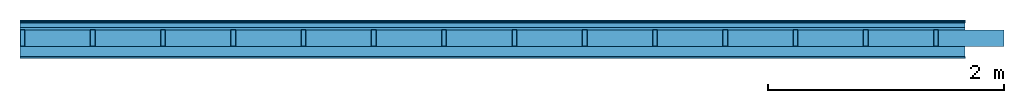
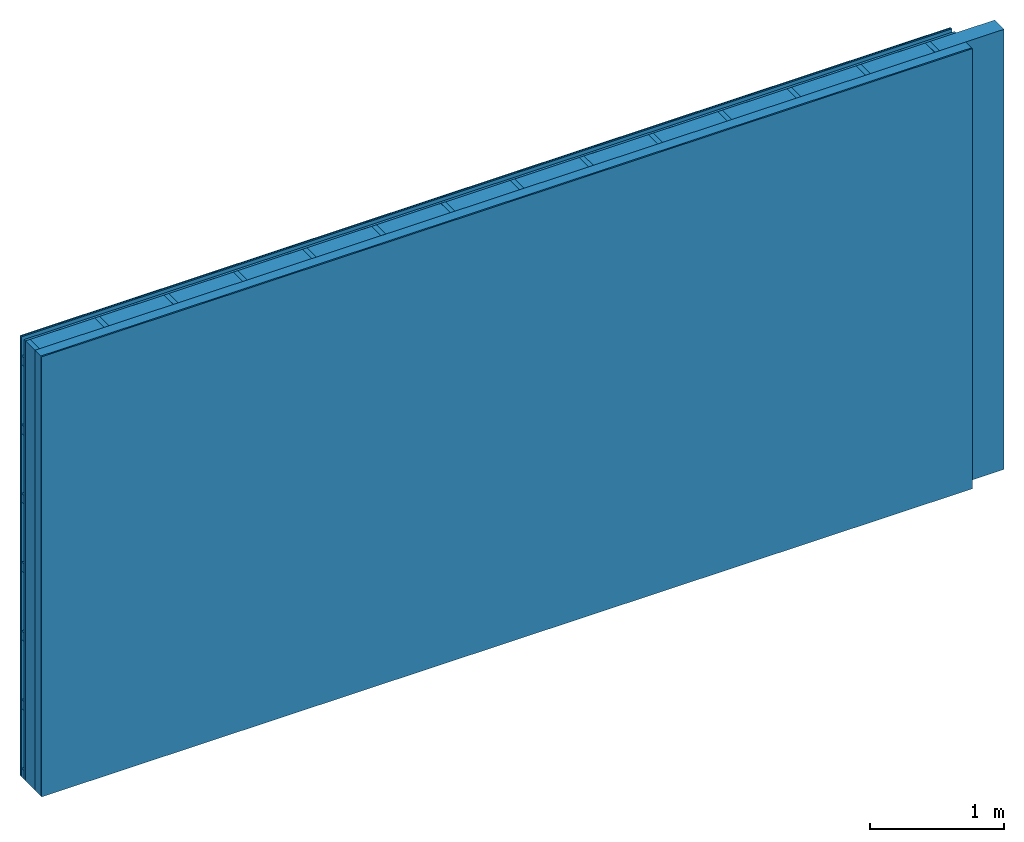
# One storey: 5 plates, 3 members, 1 element without a shape of its own.
"""IFC4 building model written with IfcOpenShell, lengths in metres."""

from ifc_helpers import new_model, si_unit, derived_unit, direction, frame, frame_2d, origin, origin_with_axes, place, context, project, spatial, rectangle, extrude, material, layer, layer_set, type_object, element, aggregate, save


model = new_model("IFC4")

# Units and contexts
plan_context = context("Plan", 3, precision=1e-05, world=origin(), true_north=direction((0.0, 1.0)))
model_context = context("Model", 3, precision=1e-05, world=origin(), true_north=direction((0.0, 1.0)))
ifc_project = project(units=[si_unit("LENGTHUNIT", "METRE"), derived_unit("SOUNDPRESSUREUNIT", [(si_unit("PRESSUREUNIT", "PASCAL", prefix="MICRO"), 0)]), si_unit("ENERGYUNIT", "JOULE", prefix="MEGA"), si_unit("MASSUNIT", "GRAM", prefix="KILO"), derived_unit("THERMALTRANSMITTANCEUNIT", [(si_unit("POWERUNIT", "WATT"), 1), (si_unit("AREAUNIT", "SQUARE_METRE"), -1), (si_unit("THERMODYNAMICTEMPERATUREUNIT", "KELVIN"), -1)]), derived_unit("AREADENSITYUNIT", [(si_unit("MASSUNIT", "GRAM", prefix="KILO"), 1), (si_unit("AREAUNIT", "SQUARE_METRE"), -1)]), derived_unit("USERDEFINED", [(si_unit("ENERGYUNIT", "JOULE", prefix="MEGA"), 1), (si_unit("AREAUNIT", "SQUARE_METRE"), -1)])], contexts=[plan_context, model_context])

# Site, building, storey
site = spatial("IfcSite", under=ifc_project)
building_placement = place(None, origin())
building = spatial("IfcBuilding", under=site, at=building_placement)
storey_placement = place(building_placement, origin())
storey = spatial("IfcBuildingStorey", under=building, at=storey_placement)

# Wall, members, plates
ifc_material_1 = material(Category="04.011")
ifc_layer_1 = layer(ifc_material_1, 0.01, Name="Surface 1")
ifc_material_2 = material(Name="mineral, cement-based building board", Category="03.003")
ifc_layer_2 = layer(ifc_material_2, 0.013, Name="Cover 1st layer")
ifc_layer_3 = layer(None, 0.04, Name="Battens / profiles (ventilation)")
ifc_material_3 = material(Category="10.009")
ifc_layer_4 = layer(ifc_material_3, 0.02, Name="outside 1st layer")
ifc_material_4 = material(Name="of the art")
ifc_layer_5 = layer(ifc_material_4, 0.0, Name="Bond")
ifc_layer_6 = layer(None, 0.14, Name="Support")
ifc_layer_7 = layer(ifc_material_4, 0.0, Name="Bond")
ifc_material_5 = material(Name="Solid timber panel")
ifc_layer_8 = layer(ifc_material_5, 0.087, Name="1st layer")
ifc_material_6 = material(Name="Plasterboard type A", Category="03.008")
ifc_layer_9 = layer(ifc_material_6, 0.0125, Name="Covering 1st layer")
ifc_material_7 = material(Name="joints", Category="04.017")
ifc_layer_10 = layer(ifc_material_7, 0.0, Name="Surface")
ifc_layer_set = layer_set([ifc_layer_1, ifc_layer_2, ifc_layer_3, ifc_layer_4, ifc_layer_5, ifc_layer_6, ifc_layer_7, ifc_layer_8, ifc_layer_9, ifc_layer_10])
wall_type = type_object("IfcWallType", Name="D0974", PredefinedType="NOTDEFINED", material=ifc_layer_set)
wall_placement = place(None, frame((0.0, 0.0, 0.0), z_axis=(0.0, -1.0, 0.0), x_axis=(1.0, 0.0, 0.0)))
wall = element("IfcWall", 1, at=wall_placement, inside=storey, type_object=wall_type, material=ifc_layer_set, Name="Wall #1")
ifc_material_8 = material()
member_1_placement = place(wall_placement, origin())
member_1 = element("IfcMember", 2, at=member_1_placement, material=ifc_material_8, Name="Battens / profiles (ventilation)", context=plan_context, shape_type="SweptSolid", body=[
    extrude(rectangle(XDim=0.08, YDim=0.04, at=frame_2d((0.04, 0.02), x_axis=(1.0, 0.0))), frame((0.0, 0.0, 0.023), z_axis=(1.0, 0.0, 0.0), x_axis=(0.0, 1.0, 0.0)), (0.0, 0.0, 1.0), 8.0),
    extrude(rectangle(XDim=0.08, YDim=0.04, at=frame_2d((0.04, 0.02), x_axis=(1.0, 0.0))), frame((0.0, 0.625, 0.023), z_axis=(1.0, 0.0, 0.0), x_axis=(0.0, 1.0, 0.0)), (0.0, 0.0, 1.0), 8.0),
    extrude(rectangle(XDim=0.08, YDim=0.04, at=frame_2d((0.04, 0.02), x_axis=(1.0, 0.0))), frame((0.0, 1.25, 0.023), z_axis=(1.0, 0.0, 0.0), x_axis=(0.0, 1.0, 0.0)), (0.0, 0.0, 1.0), 8.0),
    extrude(rectangle(XDim=0.08, YDim=0.04, at=frame_2d((0.04, 0.02), x_axis=(1.0, 0.0))), frame((0.0, 1.875, 0.023), z_axis=(1.0, 0.0, 0.0), x_axis=(0.0, 1.0, 0.0)), (0.0, 0.0, 1.0), 8.0),
    extrude(rectangle(XDim=0.08, YDim=0.04, at=frame_2d((0.04, 0.02), x_axis=(1.0, 0.0))), frame((0.0, 2.5, 0.023), z_axis=(1.0, 0.0, 0.0), x_axis=(0.0, 1.0, 0.0)), (0.0, 0.0, 1.0), 8.0),
    extrude(rectangle(XDim=0.08, YDim=0.04, at=frame_2d((0.04, 0.02), x_axis=(1.0, 0.0))), frame((0.0, 3.125, 0.023), z_axis=(1.0, 0.0, 0.0), x_axis=(0.0, 1.0, 0.0)), (0.0, 0.0, 1.0), 8.0),
    extrude(rectangle(XDim=0.08, YDim=0.04, at=frame_2d((0.04, 0.02), x_axis=(1.0, 0.0))), frame((0.0, 3.75, 0.023), z_axis=(1.0, 0.0, 0.0), x_axis=(0.0, 1.0, 0.0)), (0.0, 0.0, 1.0), 8.0),
])
ifc_material_9 = material()
member_2_placement = place(wall_placement, origin())
member_2 = element("IfcMember", 3, at=member_2_placement, material=ifc_material_9, Name="Support", context=plan_context, shape_type="SweptSolid", body=[
    extrude(rectangle(XDim=0.04, YDim=0.14, at=frame_2d((0.02, 0.07), x_axis=(1.0, 0.0))), frame((0.0, 4.0, 0.083), z_axis=(0.0, -1.0, 0.0), x_axis=(1.0, 0.0, 0.0)), (0.0, 0.0, 1.0), 4.0),
    extrude(rectangle(XDim=0.04, YDim=0.14, at=frame_2d((0.02, 0.07), x_axis=(1.0, 0.0))), frame((0.595, 4.0, 0.083), z_axis=(0.0, -1.0, 0.0), x_axis=(1.0, 0.0, 0.0)), (0.0, 0.0, 1.0), 4.0),
    extrude(rectangle(XDim=0.04, YDim=0.14, at=frame_2d((0.02, 0.07), x_axis=(1.0, 0.0))), frame((1.19, 4.0, 0.083), z_axis=(0.0, -1.0, 0.0), x_axis=(1.0, 0.0, 0.0)), (0.0, 0.0, 1.0), 4.0),
    extrude(rectangle(XDim=0.04, YDim=0.14, at=frame_2d((0.02, 0.07), x_axis=(1.0, 0.0))), frame((1.785, 4.0, 0.083), z_axis=(0.0, -1.0, 0.0), x_axis=(1.0, 0.0, 0.0)), (0.0, 0.0, 1.0), 4.0),
    extrude(rectangle(XDim=0.04, YDim=0.14, at=frame_2d((0.02, 0.07), x_axis=(1.0, 0.0))), frame((2.38, 4.0, 0.083), z_axis=(0.0, -1.0, 0.0), x_axis=(1.0, 0.0, 0.0)), (0.0, 0.0, 1.0), 4.0),
    extrude(rectangle(XDim=0.04, YDim=0.14, at=frame_2d((0.02, 0.07), x_axis=(1.0, 0.0))), frame((2.975, 4.0, 0.083), z_axis=(0.0, -1.0, 0.0), x_axis=(1.0, 0.0, 0.0)), (0.0, 0.0, 1.0), 4.0),
    extrude(rectangle(XDim=0.04, YDim=0.14, at=frame_2d((0.02, 0.07), x_axis=(1.0, 0.0))), frame((3.57, 4.0, 0.083), z_axis=(0.0, -1.0, 0.0), x_axis=(1.0, 0.0, 0.0)), (0.0, 0.0, 1.0), 4.0),
    extrude(rectangle(XDim=0.04, YDim=0.14, at=frame_2d((0.02, 0.07), x_axis=(1.0, 0.0))), frame((4.165, 4.0, 0.083), z_axis=(0.0, -1.0, 0.0), x_axis=(1.0, 0.0, 0.0)), (0.0, 0.0, 1.0), 4.0),
    extrude(rectangle(XDim=0.04, YDim=0.14, at=frame_2d((0.02, 0.07), x_axis=(1.0, 0.0))), frame((4.76, 4.0, 0.083), z_axis=(0.0, -1.0, 0.0), x_axis=(1.0, 0.0, 0.0)), (0.0, 0.0, 1.0), 4.0),
    extrude(rectangle(XDim=0.04, YDim=0.14, at=frame_2d((0.02, 0.07), x_axis=(1.0, 0.0))), frame((5.355, 4.0, 0.083), z_axis=(0.0, -1.0, 0.0), x_axis=(1.0, 0.0, 0.0)), (0.0, 0.0, 1.0), 4.0),
    extrude(rectangle(XDim=0.04, YDim=0.14, at=frame_2d((0.02, 0.07), x_axis=(1.0, 0.0))), frame((5.95, 4.0, 0.083), z_axis=(0.0, -1.0, 0.0), x_axis=(1.0, 0.0, 0.0)), (0.0, 0.0, 1.0), 4.0),
    extrude(rectangle(XDim=0.04, YDim=0.14, at=frame_2d((0.02, 0.07), x_axis=(1.0, 0.0))), frame((6.545, 4.0, 0.083), z_axis=(0.0, -1.0, 0.0), x_axis=(1.0, 0.0, 0.0)), (0.0, 0.0, 1.0), 4.0),
    extrude(rectangle(XDim=0.04, YDim=0.14, at=frame_2d((0.02, 0.07), x_axis=(1.0, 0.0))), frame((7.14, 4.0, 0.083), z_axis=(0.0, -1.0, 0.0), x_axis=(1.0, 0.0, 0.0)), (0.0, 0.0, 1.0), 4.0),
    extrude(rectangle(XDim=0.04, YDim=0.14, at=frame_2d((0.02, 0.07), x_axis=(1.0, 0.0))), frame((7.735, 4.0, 0.083), z_axis=(0.0, -1.0, 0.0), x_axis=(1.0, 0.0, 0.0)), (0.0, 0.0, 1.0), 4.0),
])
ifc_material_10 = material()
member_3_placement = place(wall_placement, origin())
member_3 = element("IfcMember", 4, at=member_3_placement, material=ifc_material_10, Name="Cavity", context=plan_context, shape_type="SweptSolid", body=[
    extrude(rectangle(XDim=0.555, YDim=0.14, at=frame_2d((0.2775, 0.07), x_axis=(1.0, 0.0))), frame((0.04, 4.0, 0.083), z_axis=(0.0, -1.0, 0.0), x_axis=(1.0, 0.0, 0.0)), (0.0, 0.0, 1.0), 4.0),
    extrude(rectangle(XDim=0.555, YDim=0.14, at=frame_2d((0.2775, 0.07), x_axis=(1.0, 0.0))), frame((0.635, 4.0, 0.083), z_axis=(0.0, -1.0, 0.0), x_axis=(1.0, 0.0, 0.0)), (0.0, 0.0, 1.0), 4.0),
    extrude(rectangle(XDim=0.555, YDim=0.14, at=frame_2d((0.2775, 0.07), x_axis=(1.0, 0.0))), frame((1.23, 4.0, 0.083), z_axis=(0.0, -1.0, 0.0), x_axis=(1.0, 0.0, 0.0)), (0.0, 0.0, 1.0), 4.0),
    extrude(rectangle(XDim=0.555, YDim=0.14, at=frame_2d((0.2775, 0.07), x_axis=(1.0, 0.0))), frame((1.825, 4.0, 0.083), z_axis=(0.0, -1.0, 0.0), x_axis=(1.0, 0.0, 0.0)), (0.0, 0.0, 1.0), 4.0),
    extrude(rectangle(XDim=0.555, YDim=0.14, at=frame_2d((0.2775, 0.07), x_axis=(1.0, 0.0))), frame((2.42, 4.0, 0.083), z_axis=(0.0, -1.0, 0.0), x_axis=(1.0, 0.0, 0.0)), (0.0, 0.0, 1.0), 4.0),
    extrude(rectangle(XDim=0.555, YDim=0.14, at=frame_2d((0.2775, 0.07), x_axis=(1.0, 0.0))), frame((3.015, 4.0, 0.083), z_axis=(0.0, -1.0, 0.0), x_axis=(1.0, 0.0, 0.0)), (0.0, 0.0, 1.0), 4.0),
    extrude(rectangle(XDim=0.555, YDim=0.14, at=frame_2d((0.2775, 0.07), x_axis=(1.0, 0.0))), frame((3.61, 4.0, 0.083), z_axis=(0.0, -1.0, 0.0), x_axis=(1.0, 0.0, 0.0)), (0.0, 0.0, 1.0), 4.0),
    extrude(rectangle(XDim=0.555, YDim=0.14, at=frame_2d((0.2775, 0.07), x_axis=(1.0, 0.0))), frame((4.205, 4.0, 0.083), z_axis=(0.0, -1.0, 0.0), x_axis=(1.0, 0.0, 0.0)), (0.0, 0.0, 1.0), 4.0),
    extrude(rectangle(XDim=0.555, YDim=0.14, at=frame_2d((0.2775, 0.07), x_axis=(1.0, 0.0))), frame((4.8, 4.0, 0.083), z_axis=(0.0, -1.0, 0.0), x_axis=(1.0, 0.0, 0.0)), (0.0, 0.0, 1.0), 4.0),
    extrude(rectangle(XDim=0.555, YDim=0.14, at=frame_2d((0.2775, 0.07), x_axis=(1.0, 0.0))), frame((5.395, 4.0, 0.083), z_axis=(0.0, -1.0, 0.0), x_axis=(1.0, 0.0, 0.0)), (0.0, 0.0, 1.0), 4.0),
    extrude(rectangle(XDim=0.555, YDim=0.14, at=frame_2d((0.2775, 0.07), x_axis=(1.0, 0.0))), frame((5.99, 4.0, 0.083), z_axis=(0.0, -1.0, 0.0), x_axis=(1.0, 0.0, 0.0)), (0.0, 0.0, 1.0), 4.0),
    extrude(rectangle(XDim=0.555, YDim=0.14, at=frame_2d((0.2775, 0.07), x_axis=(1.0, 0.0))), frame((6.585, 4.0, 0.083), z_axis=(0.0, -1.0, 0.0), x_axis=(1.0, 0.0, 0.0)), (0.0, 0.0, 1.0), 4.0),
    extrude(rectangle(XDim=0.555, YDim=0.14, at=frame_2d((0.2775, 0.07), x_axis=(1.0, 0.0))), frame((7.18, 4.0, 0.083), z_axis=(0.0, -1.0, 0.0), x_axis=(1.0, 0.0, 0.0)), (0.0, 0.0, 1.0), 4.0),
    extrude(rectangle(XDim=0.555, YDim=0.14, at=frame_2d((0.2775, 0.07), x_axis=(1.0, 0.0))), frame((7.775, 4.0, 0.083), z_axis=(0.0, -1.0, 0.0), x_axis=(1.0, 0.0, 0.0)), (0.0, 0.0, 1.0), 4.0),
])
plate_1_placement = place(wall_placement, origin())
plate_1 = element("IfcPlate", 5, at=plate_1_placement, material=ifc_material_1, Name="Surface 1", context=plan_context, shape_type="SweptSolid", body=[
    extrude(rectangle(XDim=8.0, YDim=4.0, at=frame_2d((4.0, 2.0), x_axis=(1.0, 0.0))), origin_with_axes(), (0.0, 0.0, 1.0), 0.01),
])
plate_2_placement = place(wall_placement, origin())
plate_2 = element("IfcPlate", 6, at=plate_2_placement, material=ifc_material_2, Name="Cover 1st layer", context=plan_context, shape_type="SweptSolid", body=[
    extrude(rectangle(XDim=8.0, YDim=4.0, at=frame_2d((4.0, 2.0), x_axis=(1.0, 0.0))), frame((0.0, 0.0, 0.01), z_axis=(0.0, 0.0, 1.0), x_axis=(1.0, 0.0, 0.0)), (0.0, 0.0, 1.0), 0.013),
])
plate_3_placement = place(wall_placement, origin())
plate_3 = element("IfcPlate", 7, at=plate_3_placement, material=ifc_material_3, Name="outside 1st layer", context=plan_context, shape_type="SweptSolid", body=[
    extrude(rectangle(XDim=8.0, YDim=4.0, at=frame_2d((4.0, 2.0), x_axis=(1.0, 0.0))), frame((0.0, 0.0, 0.063), z_axis=(0.0, 0.0, 1.0), x_axis=(1.0, 0.0, 0.0)), (0.0, 0.0, 1.0), 0.02),
])
plate_4_placement = place(wall_placement, origin())
plate_4 = element("IfcPlate", 8, at=plate_4_placement, material=ifc_material_5, Name="1st layer", context=plan_context, shape_type="SweptSolid", body=[
    extrude(rectangle(XDim=8.0, YDim=4.0, at=frame_2d((4.0, 2.0), x_axis=(1.0, 0.0))), frame((0.0, 0.0, 0.223), z_axis=(0.0, 0.0, 1.0), x_axis=(1.0, 0.0, 0.0)), (0.0, 0.0, 1.0), 0.087),
])
plate_5_placement = place(wall_placement, origin())
plate_5 = element("IfcPlate", 9, at=plate_5_placement, material=ifc_material_6, Name="Covering 1st layer", context=plan_context, shape_type="SweptSolid", body=[
    extrude(rectangle(XDim=8.0, YDim=4.0, at=frame_2d((4.0, 2.0), x_axis=(1.0, 0.0))), frame((0.0, 0.0, 0.31), z_axis=(0.0, 0.0, 1.0), x_axis=(1.0, 0.0, 0.0)), (0.0, 0.0, 1.0), 0.0125),
])
aggregate(wall, [plate_1, plate_2, member_1, plate_3, member_2, member_3, plate_4, plate_5])

save(model, "model.ifc")
